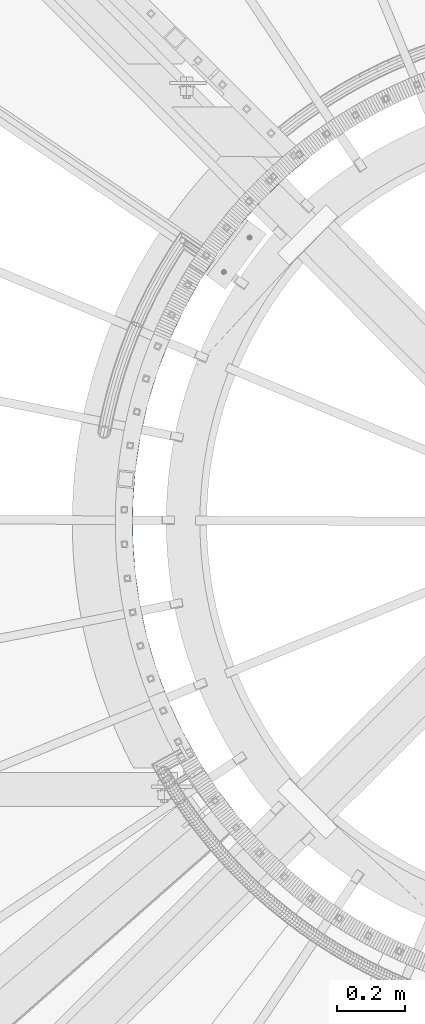
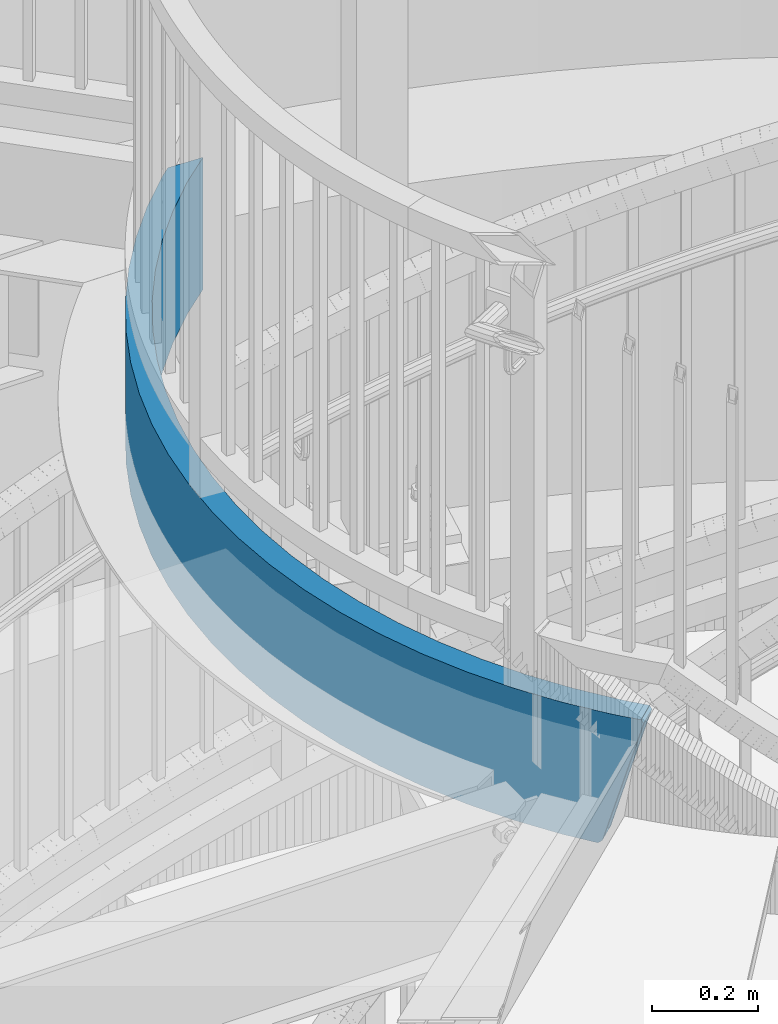
# One storey, part 346 of 975: 1 beam.
"""IFC2X3 building model written with IfcOpenShell, lengths in millimetres."""

from ifc_helpers import new_model, si_unit, frame, origin_with_axes, place, context, subcontext, project, spatial, faceted_brep, material, type_object, element, save


model = new_model("IFC2X3")

# Units and contexts
model_context = context("Model", 3, precision=1e-05, world=origin_with_axes())
body_context = subcontext(model_context, "Body", "Model", "MODEL_VIEW")
ifc_project = project(units=[si_unit("LENGTHUNIT", "METRE", prefix="MILLI"), si_unit("AREAUNIT", "SQUARE_METRE"), si_unit("VOLUMEUNIT", "CUBIC_METRE"), si_unit("MASSUNIT", "GRAM", prefix="KILO"), si_unit("TIMEUNIT", "SECOND"), si_unit("PLANEANGLEUNIT", "RADIAN"), si_unit("SOLIDANGLEUNIT", "STERADIAN"), si_unit("THERMODYNAMICTEMPERATUREUNIT", "DEGREE_CELSIUS"), si_unit("LUMINOUSINTENSITYUNIT", "LUMEN")], contexts=[model_context])

# Site, building, storey
site_placement = place(None, origin_with_axes())
site = spatial("IfcSite", under=ifc_project, at=site_placement, CompositionType="ELEMENT")
building_placement = place(site_placement, origin_with_axes())
building = spatial("IfcBuilding", under=site, at=building_placement, Name="Undefined", CompositionType="ELEMENT")
storey_placement = place(building_placement, origin_with_axes())
storey = spatial("IfcBuildingStorey", under=building, at=storey_placement, Name="Undefined", CompositionType="ELEMENT", Elevation=0.0)

# Beam
ifc_material = material()
beam_type = type_object("IfcBeamType", Name="HSS12X2X5/16", PredefinedType="NOTDEFINED")
beam_placement = place(storey_placement, frame((33726.8552187242, 2433.09053874093, 3987.82588265218), z_axis=(0.0, 0.0, 1.0), x_axis=(-0.370732707091286, 0.928739608228683, 0.0)))
element("IfcBeam", 1, at=beam_placement, inside=storey, type_object=beam_type, material=ifc_material, Name="BEAM", ObjectType="HSS12X2X5/16", context=body_context, shape_type="Brep", body=[
    faceted_brep([(306.229755971206, 58.0648056176688, -152.4), (405.043644116718, 70.555554038634, -152.4), (405.043644116718, 70.555554038634, 152.4), (306.229755971206, 58.0648056176688, 152.4), (504.50338482927, 75.8435842907384, -152.4), (504.50338482927, 75.8435842907384, 152.4), (604.08465680639, 73.9010194974835, -152.4), (604.08465680639, 73.9010194974835, 152.4), (703.262498070031, 64.7381002657276, -152.4), (703.262498070031, 64.7381002657276, 152.4), (801.514073405311, 48.4031307003388, -152.4), (801.514073405311, 48.4031307003388, 152.4), (898.32143058777, 24.9822237597436, -152.4), (898.32143058777, 24.9822237597436, 152.4), (993.174230868864, -5.40115270520255, -152.4), (993.174230868864, -5.40115270520255, 152.4), (1085.57243932565, -42.5868268359445, -152.4), (1085.57243932565, -42.5868268359445, 152.4), (1175.02896089176, -86.3787671432365, -152.4), (1175.02896089176, -86.3787671432365, 152.4), (1261.0722081735, -136.546115925117, -152.4), (1261.0722081735, -136.546115925117, 152.4), (1343.2485875142, -192.824406278021, -152.4), (1343.2485875142, -192.824406278021, 152.4), (1421.12489020108, -254.916956285393, -152.4), (1421.12489020108, -254.916956285393, 152.4), (1494.290576209, -322.496433033812, -152.4), (1494.290576209, -322.496433033812, 152.4), (1562.3599384417, -395.206578212015, -152.4), (1562.3599384417, -395.206578212015, 152.4), (1624.97413606161, -472.664086195546, -152.4), (1624.97413606161, -472.664086195546, 152.4), (1681.80308618884, -554.460624716696, -152.4), (1681.80308618884, -554.460624716696, 152.4), (1732.54720399706, -640.1649874672, -152.4), (1732.54720399706, -640.1649874672, 152.4), (1776.938982033, -729.325367285892, -152.4), (1776.938982033, -729.325367285892, 152.4), (1814.74440043384, -821.471737947679, -152.4), (1814.74440043384, -821.471737947679, 152.4), (1841.45709403489, -902.976735182703, -152.4), (1841.45709403489, -902.976735182703, 152.4), (97.2509513151454, 60.1964411812696, 152.4), (196.77034402852, 87.8447742651224, 152.4), (196.77034402852, 87.8447742651224, -152.4), (126.339141295626, 68.2776798570667, -152.4), (117.369837876304, 65.7858410133376, -144.247637679136), (97.2509513151454, 60.1964411812696, -71.3438680228387), (298.033542382058, 108.199245704345, 152.4), (298.033542382058, 108.199245704345, -152.4), (400.506717796758, 121.152552957246, 152.4), (400.506717796758, 121.152552957246, -152.4), (503.649663065027, 126.636410153762, 152.4), (503.649663065027, 126.636410153762, -152.4), (606.918640157633, 124.621908077697, 152.4), (606.918640157633, 124.621908077697, -152.4), (709.769246644184, 115.119666567229, 152.4), (709.769246644184, 115.119666567229, -152.4), (811.659285615995, 98.1797785304079, 152.4), (811.659285615995, 98.1797785304079, -152.4), (912.051623982268, 73.8915458706324, 152.4), (912.051623982268, 73.8915458706324, -152.4), (1010.41702407124, 42.3830087144161, 152.4), (1010.41702407124, 42.3830087144161, -152.4), (1106.23693360918, 3.8202704229916, 152.4), (1106.23693360918, 3.8202704229916, -152.4), (1199.00621936923, -41.593378053738, 152.4), (1199.00621936923, -41.593378053738, -152.4), (1288.2358300791, -93.6185298648415, 152.4), (1288.2358300791, -93.6185298648415, -152.4), (1373.45537454965, -151.980924337975, 152.4), (1373.45537454965, -151.980924337975, -152.4), (1454.21560143324, -216.372892797721, 152.4), (1454.21560143324, -216.372892797721, -152.4), (1530.09076753928, -286.454980500584, 152.4), (1530.09076753928, -286.454980500584, -152.4), (1600.68088222202, -361.857736136535, 152.4), (1600.68088222202, -361.857736136535, -152.4), (1665.61381600868, -442.18365946315, 152.4), (1665.61381600868, -442.18365946315, -152.4), (1724.54726235223, -527.009296805241, 152.4), (1724.54726235223, -527.009296805241, -152.4), (1777.17054216658, -615.887473372932, 152.4), (1777.17054216658, -615.887473372932, -152.4), (1823.20624163171, -708.34965063032, 152.4), (1823.20624163171, -708.34965063032, -152.4), (1862.41167463431, -803.908396287094, 152.4), (1862.41167463431, -803.908396287094, -152.4), (1872.35920697702, -834.260018935005, 152.4), (1872.35920697702, -834.260018935005, -152.4), (206.736966187906, 46.1571220286969, 144.4625), (304.949097597901, 65.8983118812102, 144.4625), (304.949097597901, 65.8983118812102, -144.4625), (206.736966187906, 46.1571220286969, -144.4625), (404.334749379226, 78.4613351196604, 144.4625), (404.334749379226, 78.4613351196604, -144.4625), (504.369990803607, 83.7799633318391, 144.4625), (504.369990803607, 83.7799633318391, -144.4625), (604.527466705025, 81.8261583381463, 144.4625), (604.527466705025, 81.8261583381463, -144.4625), (704.279177534743, 72.6102200003406, 144.4625), (704.279177534743, 72.6102200003406, -144.4625), (803.09926281323, 56.1807319237814, 144.4625), (803.09926281323, 56.1807319237814, -144.4625), (900.466773305661, 32.6243053395738, 144.4625), (900.466773305661, 32.6243053395738, -144.4625), (995.868417306738, 2.06512251661843, 144.4625), (995.868417306738, 2.06512251661843, -144.4625), (1088.80126655745, -35.3357178892329, 144.4625), (1088.80126655745, -35.3357178892329, -144.4625), (1178.77540752886, -79.3810500980035, 144.4625), (1178.77540752886, -79.3810500980035, -144.4625), (1265.31652409625, -129.838680603192, 144.4625), (1265.31652409625, -129.838680603192, -144.4625), (1347.96839798848, -186.442612224891, 144.4625), (1347.96839798848, -186.442612224891, -144.4625), (1426.29531383111, -248.894446365441, 144.4625), (1426.29531383111, -248.894446365441, -144.4625), (1499.88435610435, -316.864956075497, 144.4625), (1499.88435610435, -316.864956075497, -144.4625), (1568.34758590737, -389.995821637727, 144.4625), (1568.34758590737, -389.995821637727, -144.4625), (1631.32408605334, -467.901519518608, 144.4625), (1631.32408605334, -467.901519518608, -144.4625), (1688.48186371437, -550.171354730526, 144.4625), (1688.48186371437, -550.171354730526, -144.4625), (1739.51960058604, -636.371625889966, 144.4625), (1739.51960058604, -636.371625889966, -144.4625), (1784.1682413453, -726.047911558453, 144.4625), (1784.1682413453, -726.047911558453, -144.4625), (1822.19241202766, -818.727465813208, -144.4625), (1846.28554918209, -892.239748268992, -144.4625), (1867.53075182981, -844.997005848702, -144.4625), (1854.96366304049, -806.652668421557, -144.4625), (1815.97698231941, -711.627106357751, -144.4625), (1770.19814557759, -619.680834950166, -144.4625), (1717.8684848267, -531.2985667914, -144.4625), (1659.26386601695, -446.946226140088, -144.4625), (1594.69323475634, -367.06849271083, -144.4625), (1524.49698764392, -292.086457458903, -144.4625), (1449.04517780321, -222.395402717673, -144.4625), (1368.73556407536, -158.362718391109, -144.4625), (1283.99151415635, -100.325965186759, -144.4625), (1195.25977273212, -48.5910950989673, -144.4625), (1103.00810637738, -3.43083852372001, -144.4625), (1007.72283763337, 34.9167334926024, -144.4625), (909.906281264377, 66.2494642908096, -144.4625), (810.074096208074, 90.4021773069544, -144.4625), (708.752567179472, 107.247546832616, -144.4625), (606.475830259002, 116.696769237034, -144.4625), (503.78305709069, 118.700031112665, -144.4625), (401.215612534252, 113.246771876209, -144.4625), (299.314200755362, 100.365739440804, -144.4625), (198.616014798778, 80.1248386657826, -144.4625), (120.31291650777, 58.3707856714827, -144.4625), (132.222331147261, 25.4555743900492, -144.4625), (1822.19241202766, -818.727465813208, 144.4625), (1846.28554918209, -892.239748268992, 144.4625), (1867.53075182981, -844.997005848702, 144.4625), (1854.96366304049, -806.652668421557, 144.4625), (1815.97698231941, -711.627106357751, 144.4625), (1770.19814557759, -619.680834950166, 144.4625), (1717.8684848267, -531.2985667914, 144.4625), (1659.26386601695, -446.946226140088, 144.4625), (1594.69323475634, -367.06849271083, 144.4625), (1524.49698764392, -292.086457458903, 144.4625), (1449.04517780321, -222.395402717673, 144.4625), (1368.73556407536, -158.362718391109, 144.4625), (1283.99151415635, -100.325965186759, 144.4625), (1195.25977273212, -48.5910950989673, 144.4625), (1103.00810637738, -3.43083852372001, 144.4625), (1007.72283763337, 34.9167334926024, 144.4625), (909.906281264377, 66.2494642908096, 144.4625), (810.074096208074, 90.4021773069544, 144.4625), (708.752567179472, 107.247546832616, 144.4625), (606.475830259002, 116.696769237034, 144.4625), (503.78305709069, 118.700031112665, 144.4625), (401.215612534252, 113.246771876209, 144.4625), (299.314200755362, 100.365739440804, 144.4625), (198.616014798778, 80.1248386657826, 144.4625), (99.6519046711255, 52.6307733830872, 144.4625), (41.7297596471089, 31.9061996344208, 144.4625), (99.6519046711255, 52.6307733830872, -70.3709902784453), (39.1449688817684, 39.4060903115023, 144.672323069063), (43.3457731614617, 40.9091402773156, 152.4), (112.617052793412, 11.7761672728739, 152.4), (208.582636958163, 38.4371864293571, 152.4), (60.6184237044017, -6.82896937974147, 152.4), (208.582636958163, 38.4371864293571, -152.4), (143.66192622579, 20.4010089022486, -152.4), (134.374390390594, 17.8207591911269, -143.958390472838), (131.717429060238, 25.3153032258488, -144.003585348822), (110.216099437434, 19.3418350710599, 144.4625), (110.216099437434, 19.3418350710599, -66.0903282031063), (53.6047068953812, -0.913750754803914, 144.4625), (56.2626104836054, -8.3874816256648, 144.387173145746), (112.617052793412, 11.7761672728739, -65.1174504587107)], [[[0, 1, 2, 3]], [[1, 4, 5, 2]], [[4, 6, 7, 5]], [[6, 8, 9, 7]], [[8, 10, 11, 9]], [[10, 12, 13, 11]], [[12, 14, 15, 13]], [[14, 16, 17, 15]], [[16, 18, 19, 17]], [[18, 20, 21, 19]], [[20, 22, 23, 21]], [[22, 24, 25, 23]], [[24, 26, 27, 25]], [[26, 28, 29, 27]], [[28, 30, 31, 29]], [[30, 32, 33, 31]], [[32, 34, 35, 33]], [[34, 36, 37, 35]], [[36, 38, 39, 37]], [[39, 38, 40, 41]], [[42, 43, 44, 45, 46, 47]], [[43, 48, 49, 44]], [[48, 50, 51, 49]], [[50, 52, 53, 51]], [[52, 54, 55, 53]], [[54, 56, 57, 55]], [[56, 58, 59, 57]], [[58, 60, 61, 59]], [[60, 62, 63, 61]], [[62, 64, 65, 63]], [[64, 66, 67, 65]], [[66, 68, 69, 67]], [[68, 70, 71, 69]], [[70, 72, 73, 71]], [[72, 74, 75, 73]], [[74, 76, 77, 75]], [[76, 78, 79, 77]], [[78, 80, 81, 79]], [[80, 82, 83, 81]], [[82, 84, 85, 83]], [[84, 86, 87, 85]], [[87, 86, 88, 89]], [[90, 91, 92, 93]], [[91, 94, 95, 92]], [[94, 96, 97, 95]], [[96, 98, 99, 97]], [[98, 100, 101, 99]], [[100, 102, 103, 101]], [[102, 104, 105, 103]], [[104, 106, 107, 105]], [[106, 108, 109, 107]], [[108, 110, 111, 109]], [[110, 112, 113, 111]], [[112, 114, 115, 113]], [[114, 116, 117, 115]], [[116, 118, 119, 117]], [[118, 120, 121, 119]], [[120, 122, 123, 121]], [[122, 124, 125, 123]], [[124, 126, 127, 125]], [[126, 128, 129, 127]], [[93, 92, 95, 97, 99, 101, 103, 105, 107, 109, 111, 113, 115, 117, 119, 121, 123, 125, 127, 129, 130, 131, 132, 133, 134, 135, 136, 137, 138, 139, 140, 141, 142, 143, 144, 145, 146, 147, 148, 149, 150, 151, 152, 153, 154, 155]], [[128, 156, 130, 129]], [[130, 156, 157, 131]], [[40, 89, 88, 41], [131, 157, 158, 132]], [[159, 133, 132, 158]], [[134, 133, 159, 160]], [[135, 134, 160, 161]], [[136, 135, 161, 162]], [[137, 136, 162, 163]], [[138, 137, 163, 164]], [[139, 138, 164, 165]], [[140, 139, 165, 166]], [[141, 140, 166, 167]], [[142, 141, 167, 168]], [[143, 142, 168, 169]], [[144, 143, 169, 170]], [[145, 144, 170, 171]], [[146, 145, 171, 172]], [[147, 146, 172, 173]], [[148, 147, 173, 174]], [[149, 148, 174, 175]], [[150, 149, 175, 176]], [[151, 150, 176, 177]], [[152, 151, 177, 178]], [[153, 152, 178, 179]], [[180, 181, 182]], [[153, 179, 180, 182, 154]], [[181, 183, 47, 46, 154, 182]], [[184, 42, 47, 183]], [[185, 186, 3, 2, 5, 7, 9, 11, 13, 15, 17, 19, 21, 23, 25, 27, 29, 31, 33, 35, 37, 39, 41, 88, 86, 84, 82, 80, 78, 76, 74, 72, 70, 68, 66, 64, 62, 60, 58, 56, 54, 52, 50, 48, 43, 42, 184, 187]], [[188, 0, 3, 186]], [[44, 49, 51, 53, 55, 57, 59, 61, 63, 65, 67, 69, 71, 73, 75, 77, 79, 81, 83, 85, 87, 89, 40, 38, 36, 34, 32, 30, 28, 26, 24, 22, 20, 18, 16, 14, 12, 10, 8, 6, 4, 1, 0, 188, 189, 45]], [[155, 154, 46, 45, 189, 190, 191]], [[192, 90, 93, 155, 191, 193]], [[192, 193, 194]], [[180, 179, 178, 177, 176, 175, 174, 173, 172, 171, 170, 169, 168, 167, 166, 165, 164, 163, 162, 161, 160, 159, 158, 157, 156, 128, 126, 124, 122, 120, 118, 116, 114, 112, 110, 108, 106, 104, 102, 100, 98, 96, 94, 91, 90, 192, 194, 181]], [[187, 184, 183, 181, 194, 195]], [[185, 187, 195, 196]], [[189, 188, 186, 185, 196, 190]], [[195, 194, 193, 191, 190, 196]]]),
])

save(model, "model.ifc")
